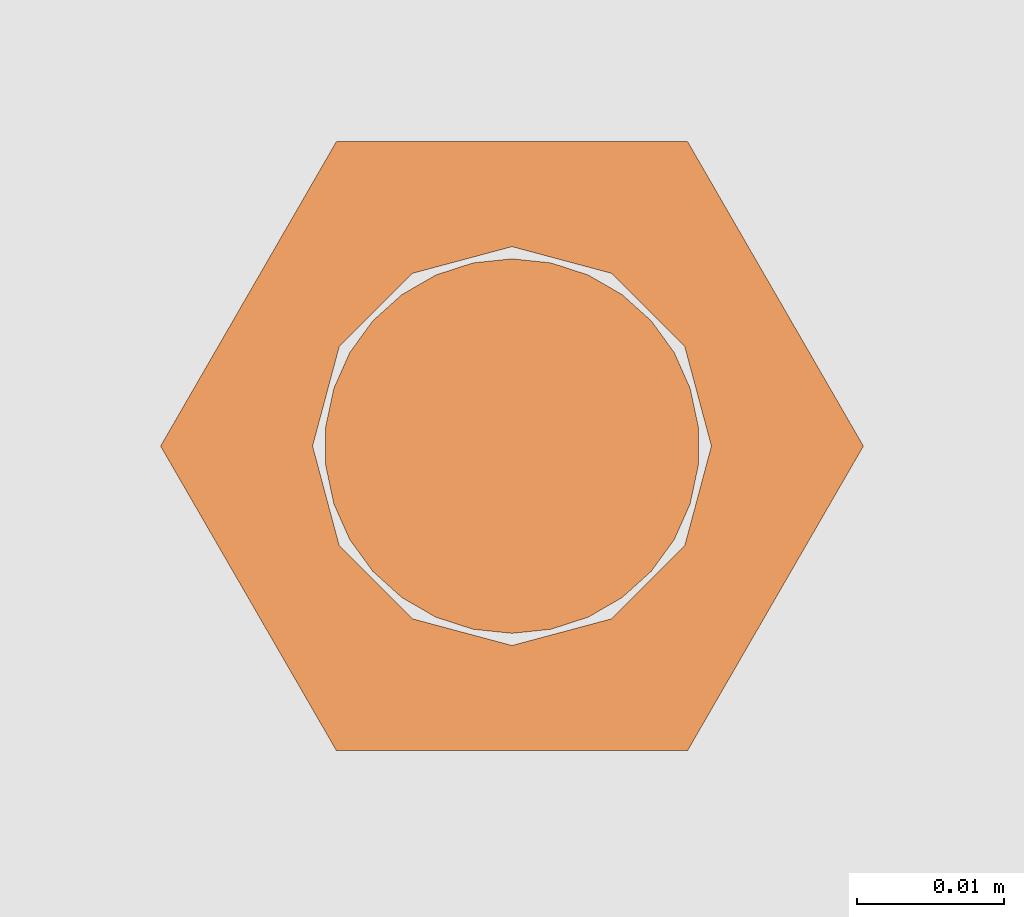
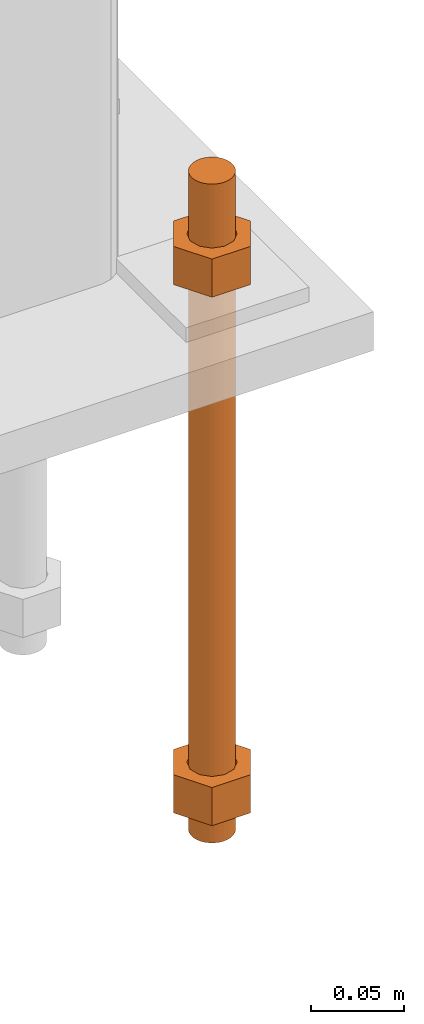
# One storey, part 23 of 89: 1 proxy.
"""IFC4 building model written with IfcOpenShell, lengths in feet."""

from ifc_helpers import new_model, entity, si_unit, converted_unit, derived_unit, direction, frame, origin, place, context, subcontext, project, spatial, faceted_brep, source, transform, mapped, material, constituent, constituent_set, type_object, type_shapes, element, save


model = new_model("IFC4")

# Units and contexts
model_context = context("Model", 3, precision=0.0001, world=origin(), true_north=direction((6.12303176911189e-17, 1.0)))
body_context = subcontext(model_context, "Body", "Model", "MODEL_VIEW")
ifc_project = project(units=[converted_unit("LENGTHUNIT", "FOOT", entity("IfcRatioMeasure", 0.3048), si_unit("LENGTHUNIT", "METRE"), dimensions=[1, 0, 0, 0, 0, 0, 0]), converted_unit("AREAUNIT", "SQUARE FOOT", entity("IfcRatioMeasure", 0.09290304), si_unit("AREAUNIT", "SQUARE_METRE"), dimensions=[2, 0, 0, 0, 0, 0, 0]), converted_unit("VOLUMEUNIT", "CUBIC FOOT", entity("IfcRatioMeasure", 0.028316846592), si_unit("VOLUMEUNIT", "CUBIC_METRE"), dimensions=[3, 0, 0, 0, 0, 0, 0]), si_unit("PLANEANGLEUNIT", "RADIAN"), si_unit("MASSUNIT", "GRAM", prefix="KILO"), derived_unit("MASSDENSITYUNIT", [(si_unit("MASSUNIT", "GRAM", prefix="KILO"), 1), (si_unit("LENGTHUNIT", "METRE"), -3)]), derived_unit("MOMENTOFINERTIAUNIT", [(si_unit("LENGTHUNIT", "METRE"), 4)]), si_unit("TIMEUNIT", "SECOND"), si_unit("FREQUENCYUNIT", "HERTZ"), si_unit("THERMODYNAMICTEMPERATUREUNIT", "DEGREE_CELSIUS"), derived_unit("THERMALTRANSMITTANCEUNIT", [(si_unit("MASSUNIT", "GRAM", prefix="KILO"), 1), (si_unit("THERMODYNAMICTEMPERATUREUNIT", "KELVIN"), -1), (si_unit("TIMEUNIT", "SECOND"), -3)]), derived_unit("VOLUMETRICFLOWRATEUNIT", [(si_unit("LENGTHUNIT", "METRE"), 3), (si_unit("TIMEUNIT", "SECOND"), -1)]), si_unit("ELECTRICCURRENTUNIT", "AMPERE"), si_unit("ELECTRICVOLTAGEUNIT", "VOLT"), si_unit("POWERUNIT", "WATT"), si_unit("FORCEUNIT", "NEWTON"), si_unit("ILLUMINANCEUNIT", "LUX"), si_unit("LUMINOUSFLUXUNIT", "LUMEN"), si_unit("LUMINOUSINTENSITYUNIT", "CANDELA"), derived_unit("USERDEFINED", [(si_unit("MASSUNIT", "GRAM", prefix="KILO"), -1), (si_unit("LENGTHUNIT", "METRE"), -2), (si_unit("TIMEUNIT", "SECOND"), 3), (si_unit("LUMINOUSFLUXUNIT", "LUMEN"), 1)]), derived_unit("LINEARVELOCITYUNIT", [(si_unit("LENGTHUNIT", "METRE"), 1), (si_unit("TIMEUNIT", "SECOND"), -1)]), si_unit("PRESSUREUNIT", "PASCAL"), derived_unit("USERDEFINED", [(si_unit("LENGTHUNIT", "METRE"), -2), (si_unit("MASSUNIT", "GRAM", prefix="KILO"), 1), (si_unit("TIMEUNIT", "SECOND"), -2)]), derived_unit("LINEARFORCEUNIT", [(si_unit("MASSUNIT", "GRAM", prefix="KILO"), 1), (si_unit("LENGTHUNIT", "METRE"), 1), (si_unit("TIMEUNIT", "SECOND"), -2), (si_unit("LENGTHUNIT", "METRE"), -1)]), derived_unit("PLANARFORCEUNIT", [(si_unit("MASSUNIT", "GRAM", prefix="KILO"), 1), (si_unit("LENGTHUNIT", "METRE"), 1), (si_unit("TIMEUNIT", "SECOND"), -2), (si_unit("LENGTHUNIT", "METRE"), -2)])], contexts=[model_context])

# Site, building, storey
site_placement = place(None, origin())
site = spatial("IfcSite", under=ifc_project, at=site_placement, CompositionType="ELEMENT")
building_placement = place(site_placement, frame((-472.238160486, -49.138065117, 0.0)))
building = spatial("IfcBuilding", under=site, at=building_placement, CompositionType="ELEMENT")
storey_placement = place(building_placement, origin())
storey = spatial("IfcBuildingStorey", under=building, at=storey_placement, Name="Level 1", CompositionType="ELEMENT", Elevation=0.0)

# Proxy
ifc_material_1 = material(Name="Color 7721", Category="Materials")
ifc_constituent_1 = constituent(ifc_material_1, Name="Color 7721", Category="Materials")
ifc_material_2 = material(Name="Color 7720", Category="Materials")
ifc_constituent_2 = constituent(ifc_material_2, Name="Color 7720", Category="Materials")
ifc_constituent_set = constituent_set(constituents=[ifc_constituent_1, ifc_constituent_2])
building_element_proxy_type = type_object("IfcBuildingElementProxyType", Name="rb2", PredefinedType="NOTDEFINED", material=ifc_material_1)
shared_shape = source(origin(), body_context, "Body", "Brep", [
    faceted_brep([(0.122545547339314, 0.0677083333333712, 0.0626666666666664), (0.156365697905585, 0.0677083333333712, 0.0626666666666664), (0.117274273429189, 0.135416666666742, 0.0626666666666664), (0.0390914244764531, 0.135416666666742, 0.0626666666666664), (0.0, 0.0677083333333712, 0.0626666666666664), (0.0338201505663278, 0.0677083333333712, 0.0626666666666664), (0.0397636251697122, 0.089889682526632, 0.0626666666666664), (0.0560014997595886, 0.106127557116452, 0.0626666666666664), (0.0781828489528209, 0.112071031719893, 0.0626666666666664), (0.100364198146053, 0.106127557116452, 0.0626666666666664), (0.11660207273593, 0.089889682526632, 0.0626666666666664), (0.117274273429189, 0.0, 0.0626666666666664), (0.0390914244764531, 0.0, 0.0626666666666664), (0.0397636251697122, 0.0455269841401105, 0.0626666666666664), (0.0560014997595886, 0.029289109550291, 0.0626666666666664), (0.0781828489528209, 0.0233456349468497, 0.0626666666666664), (0.100364198146053, 0.029289109550291, 0.0626666666666664), (0.11660207273593, 0.0455269841401105, 0.0626666666666664), (0.0, 0.0677083333333712, 0.144697916666667), (0.0390914244764815, 0.135416666666742, 0.144697916666667), (0.117274273429189, 0.135416666666742, 0.144697916666667), (0.156365697905613, 0.0677083333333712, 0.144697916666667), (0.117274273429217, 0.0, 0.144697916666667), (0.0390914244764531, 0.0, 0.144697916666667), (0.122545547339314, 0.0677083333333712, 0.144697916666666), (0.0338201505663278, 0.0677083333333712, 0.144697916666666), (0.0397636251697122, 0.0455269841401105, 0.144697916666666), (0.0560014997595886, 0.029289109550291, 0.144697916666666), (0.0781828489528209, 0.0233456349468497, 0.144697916666666), (0.100364198146053, 0.029289109550291, 0.144697916666666), (0.11660207273593, 0.0455269841401105, 0.144697916666666), (0.0397636251697122, 0.089889682526632, 0.144697916666666), (0.0560014997595886, 0.106127557116452, 0.144697916666666), (0.0781828489528209, 0.112071031719893, 0.144697916666666), (0.100364198146053, 0.106127557116452, 0.144697916666666), (0.11660207273593, 0.089889682526632, 0.144697916666666)], [[[0, 1, 2, 3, 4, 5, 6, 7, 8, 9, 10]], [[1, 11, 12, 4, 5, 13, 14, 15, 16, 17, 0]], [[4, 18, 19, 3]], [[3, 19, 20, 2]], [[2, 20, 21, 1]], [[1, 21, 22, 11]], [[11, 22, 23, 12]], [[12, 23, 18, 4]], [[24, 21, 22, 23, 18, 25, 26, 27, 28, 29, 30]], [[21, 20, 19, 18, 25, 31, 32, 33, 34, 35, 24]], [[25, 5, 6, 31]], [[31, 6, 7, 32]], [[32, 7, 8, 33]], [[33, 8, 9, 34]], [[34, 9, 10, 35]], [[35, 10, 0, 24]], [[24, 0, 17, 30]], [[30, 17, 16, 29]], [[29, 16, 15, 28]], [[28, 15, 14, 27]], [[27, 14, 13, 26]], [[26, 13, 5, 25]]]),
    faceted_brep([(0.0338201505663278, 0.0677083333333712, 1.28108333333333), (0.0, 0.0677083333333712, 1.28108333333333), (0.0390914244764531, 0.135416666666742, 1.28108333333333), (0.117274273429189, 0.135416666666742, 1.28108333333333), (0.156365697905585, 0.0677083333333712, 1.28108333333333), (0.122545547339314, 0.0677083333333712, 1.28108333333333), (0.11660207273593, 0.089889682526632, 1.28108333333333), (0.100364198146053, 0.106127557116452, 1.28108333333333), (0.0781828489528209, 0.112071031719893, 1.28108333333333), (0.0560014997595886, 0.106127557116452, 1.28108333333333), (0.0397636251697122, 0.089889682526632, 1.28108333333333), (0.0390914244764531, 0.0, 1.28108333333333), (0.117274273429189, 0.0, 1.28108333333333), (0.11660207273593, 0.0455269841401105, 1.28108333333333), (0.100364198146053, 0.029289109550291, 1.28108333333333), (0.0781828489528209, 0.0233456349468497, 1.28108333333333), (0.0560014997595886, 0.029289109550291, 1.28108333333333), (0.0397636251697122, 0.0455269841401105, 1.28108333333333), (0.156365697905557, 0.0677083333333712, 1.19905208333333), (0.11727427342916, 0.135416666666742, 1.19905208333333), (0.0390914244764531, 0.135416666666742, 1.19905208333333), (0.0, 0.0677083333333712, 1.19905208333333), (0.0390914244764247, 0.0, 1.19905208333333), (0.117274273429189, 0.0, 1.19905208333333), (0.0338201505663278, 0.0677083333333712, 1.19905208333333), (0.122545547339314, 0.0677083333333712, 1.19905208333333), (0.11660207273593, 0.0455269841401105, 1.19905208333333), (0.100364198146053, 0.029289109550291, 1.19905208333333), (0.0781828489528209, 0.0233456349468497, 1.19905208333333), (0.0560014997595886, 0.029289109550291, 1.19905208333333), (0.0397636251697122, 0.0455269841401105, 1.19905208333333), (0.11660207273593, 0.089889682526632, 1.19905208333333), (0.100364198146053, 0.106127557116452, 1.19905208333333), (0.0781828489528209, 0.112071031719893, 1.19905208333333), (0.0560014997595886, 0.106127557116452, 1.19905208333333), (0.0397636251697122, 0.089889682526632, 1.19905208333333)], [[[0, 1, 2, 3, 4, 5, 6, 7, 8, 9, 10]], [[1, 11, 12, 4, 5, 13, 14, 15, 16, 17, 0]], [[4, 18, 19, 3]], [[3, 19, 20, 2]], [[2, 20, 21, 1]], [[1, 21, 22, 11]], [[11, 22, 23, 12]], [[12, 23, 18, 4]], [[24, 21, 22, 23, 18, 25, 26, 27, 28, 29, 30]], [[21, 20, 19, 18, 25, 31, 32, 33, 34, 35, 24]], [[25, 5, 6, 31]], [[31, 6, 7, 32]], [[32, 7, 8, 33]], [[33, 8, 9, 34]], [[34, 9, 10, 35]], [[35, 10, 0, 24]], [[24, 0, 17, 30]], [[30, 17, 16, 29]], [[29, 16, 15, 28]], [[28, 15, 14, 27]], [[27, 14, 13, 26]], [[26, 13, 5, 25]]]),
    faceted_brep([(0.0781828489528209, 0.0260416666667425, 0.0), (0.0695198618354027, 0.0269521833027966, 0.0), (0.06123548882465, 0.029643939264929, 0.0), (0.0536917967739612, 0.0339992919010683, 0.0), (0.0472184812246041, 0.0398278914017283, 0.0), (0.0420984571284748, 0.046875, 0.0), (0.038555494107186, 0.0548326252344395, 0.0), (0.0367444366458187, 0.0633529806972319, 0.0), (0.0367444366458187, 0.0720636859695105, 0.0), (0.038555494107186, 0.0805840414323029, 0.0), (0.0420984571284748, 0.0885416666667425, 0.0), (0.0472184812246041, 0.0955887752650142, 0.0), (0.0536917967739612, 0.101417374765674, 0.0), (0.06123548882465, 0.105772727401813, 0.0), (0.0695198618354027, 0.108464483363946, 0.0), (0.0781828489528209, 0.109375, 0.0), (0.0868458360702391, 0.108464483363946, 0.0), (0.0951302090809918, 0.105772727401813, 0.0), (0.102673901131681, 0.101417374765674, 0.0), (0.109147216681038, 0.0955887752650142, 0.0), (0.114267240777167, 0.0885416666667425, 0.0), (0.117810203798456, 0.0805840414323029, 0.0), (0.119621261259823, 0.0720636859695105, 0.0), (0.119621261259823, 0.0633529806972319, 0.0), (0.117810203798456, 0.0548326252344395, 0.0), (0.114267240777167, 0.046875, 0.0), (0.109147216681038, 0.0398278914017283, 0.0), (0.102673901131681, 0.0339992919010683, 0.0), (0.0951302090809918, 0.029643939264929, 0.0), (0.0868458360702391, 0.0269521833027966, 0.0), (0.0868458360702391, 0.0269521833027966, 1.41666666666667), (0.0951302090809918, 0.029643939264929, 1.41666666666667), (0.102673901131681, 0.0339992919010683, 1.41666666666667), (0.109147216681038, 0.0398278914017283, 1.41666666666667), (0.114267240777167, 0.046875, 1.41666666666667), (0.117810203798456, 0.0548326252344395, 1.41666666666667), (0.119621261259823, 0.0633529806972319, 1.41666666666667), (0.119621261259823, 0.0720636859695105, 1.41666666666667), (0.117810203798456, 0.0805840414323029, 1.41666666666667), (0.114267240777167, 0.0885416666667425, 1.41666666666667), (0.109147216681038, 0.0955887752650142, 1.41666666666667), (0.102673901131681, 0.101417374765674, 1.41666666666667), (0.0951302090809918, 0.105772727401813, 1.41666666666667), (0.0868458360702391, 0.108464483363946, 1.41666666666667), (0.0781828489528209, 0.109375, 1.41666666666667), (0.0695198618354027, 0.108464483363946, 1.41666666666667), (0.06123548882465, 0.105772727401813, 1.41666666666667), (0.0536917967739612, 0.101417374765674, 1.41666666666667), (0.0472184812246041, 0.0955887752650142, 1.41666666666667), (0.0420984571284748, 0.0885416666667425, 1.41666666666667), (0.038555494107186, 0.0805840414323029, 1.41666666666667), (0.0367444366458187, 0.0720636859695105, 1.41666666666667), (0.0367444366458187, 0.0633529806972319, 1.41666666666667), (0.038555494107186, 0.0548326252344395, 1.41666666666667), (0.0420984571284748, 0.046875, 1.41666666666667), (0.0472184812246041, 0.0398278914017283, 1.41666666666667), (0.0536917967739612, 0.0339992919010683, 1.41666666666667), (0.06123548882465, 0.029643939264929, 1.41666666666667), (0.0695198618354027, 0.0269521833027966, 1.41666666666667), (0.0781828489528209, 0.0260416666667425, 1.41666666666667), (0.0695198618354027, 0.0269521833027966, 0.25), (0.0781828489528209, 0.0260416666667425, 0.25), (0.06123548882465, 0.029643939264929, 0.25), (0.0536917967739612, 0.0339992919010683, 0.25), (0.047218481224661, 0.0398278914017283, 0.25), (0.0420984571284464, 0.046875, 0.25), (0.038555494107186, 0.0548326252344395, 0.25), (0.0367444366457903, 0.0633529806972319, 0.25), (0.0367444366458187, 0.0720636859695105, 0.25), (0.038555494107186, 0.0805840414323029, 0.25), (0.0420984571285032, 0.0885416666667425, 0.25), (0.0472184812246041, 0.0955887752650142, 0.25), (0.0536917967739896, 0.101417374765674, 0.25), (0.06123548882465, 0.105772727401813, 0.25), (0.0695198618354027, 0.108464483363946, 0.25), (0.0781828489528209, 0.109375, 0.25), (0.0868458360702391, 0.108464483363946, 0.25), (0.0951302090809918, 0.105772727401813, 0.25), (0.102673901131681, 0.101417374765674, 0.25), (0.109147216681095, 0.0955887752650142, 0.25), (0.114267240777167, 0.0885416666667425, 0.25), (0.117810203798371, 0.0805840414323029, 0.25), (0.119621261259823, 0.0720636859695105, 0.25), (0.119621261259823, 0.0633529806972319, 0.25), (0.117810203798456, 0.0548326252344395, 0.25), (0.114267240777224, 0.046875, 0.25), (0.109147216681009, 0.0398278914017283, 0.25), (0.102673901131709, 0.0339992919010683, 0.25), (0.0951302090809918, 0.029643939264929, 0.25), (0.0868458360702391, 0.0269521833027966, 0.25), (0.0695198618354027, 0.0269521833027966, 0.916666666666667), (0.0781828489528209, 0.0260416666667425, 0.916666666666667), (0.06123548882465, 0.029643939264929, 0.916666666666667), (0.0536917967739612, 0.0339992919010683, 0.916666666666667), (0.047218481224661, 0.0398278914017283, 0.916666666666667), (0.0420984571284464, 0.046875, 0.916666666666667), (0.038555494107186, 0.0548326252344395, 0.916666666666667), (0.0367444366457903, 0.0633529806972319, 0.916666666666667), (0.0367444366458187, 0.0720636859695105, 0.916666666666667), (0.038555494107186, 0.0805840414323029, 0.916666666666667), (0.0420984571285032, 0.0885416666667425, 0.916666666666667), (0.0472184812246041, 0.0955887752650142, 0.916666666666667), (0.0536917967739896, 0.101417374765674, 0.916666666666667), (0.06123548882465, 0.105772727401813, 0.916666666666667), (0.0695198618354027, 0.108464483363946, 0.916666666666667), (0.0781828489528209, 0.109375, 0.916666666666667), (0.0868458360702391, 0.108464483363946, 0.916666666666667), (0.0951302090809918, 0.105772727401813, 0.916666666666667), (0.102673901131681, 0.101417374765674, 0.916666666666667), (0.109147216681095, 0.0955887752650142, 0.916666666666667), (0.114267240777167, 0.0885416666667425, 0.916666666666667), (0.117810203798371, 0.0805840414323029, 0.916666666666667), (0.119621261259823, 0.0720636859695105, 0.916666666666667), (0.119621261259823, 0.0633529806972319, 0.916666666666667), (0.117810203798456, 0.0548326252344395, 0.916666666666667), (0.114267240777224, 0.046875, 0.916666666666667), (0.109147216681009, 0.0398278914017283, 0.916666666666667), (0.102673901131709, 0.0339992919010683, 0.916666666666667), (0.0951302090809918, 0.029643939264929, 0.916666666666667), (0.0868458360702391, 0.0269521833027966, 0.916666666666667)], [[[0, 1, 2, 3, 4, 5, 6, 7, 8, 9, 10, 11, 12, 13, 14, 15, 16, 17, 18, 19, 20, 21, 22, 23, 24, 25, 26, 27, 28, 29]], [[30, 31, 32, 33, 34, 35, 36, 37, 38, 39, 40, 41, 42, 43, 44, 45, 46, 47, 48, 49, 50, 51, 52, 53, 54, 55, 56, 57, 58, 59]], [[60, 1, 0, 61]], [[62, 2, 1, 60]], [[63, 3, 2, 62]], [[64, 4, 3, 63]], [[65, 5, 4, 64]], [[66, 6, 5, 65]], [[67, 7, 6, 66]], [[68, 8, 7, 67]], [[69, 9, 8, 68]], [[70, 10, 9, 69]], [[71, 11, 10, 70]], [[72, 12, 11, 71]], [[73, 13, 12, 72]], [[74, 14, 13, 73]], [[75, 15, 14, 74]], [[76, 16, 15, 75]], [[77, 17, 16, 76]], [[78, 18, 17, 77]], [[79, 19, 18, 78]], [[80, 20, 19, 79]], [[81, 21, 20, 80]], [[82, 22, 21, 81]], [[83, 23, 22, 82]], [[84, 24, 23, 83]], [[85, 25, 24, 84]], [[86, 26, 25, 85]], [[87, 27, 26, 86]], [[88, 28, 27, 87]], [[89, 29, 28, 88]], [[61, 0, 29, 89]], [[90, 60, 61, 91]], [[92, 62, 60, 90]], [[93, 63, 62, 92]], [[94, 64, 63, 93]], [[95, 65, 64, 94]], [[96, 66, 65, 95]], [[97, 67, 66, 96]], [[98, 68, 67, 97]], [[99, 69, 68, 98]], [[100, 70, 69, 99]], [[101, 71, 70, 100]], [[102, 72, 71, 101]], [[103, 73, 72, 102]], [[104, 74, 73, 103]], [[105, 75, 74, 104]], [[106, 76, 75, 105]], [[107, 77, 76, 106]], [[108, 78, 77, 107]], [[109, 79, 78, 108]], [[110, 80, 79, 109]], [[111, 81, 80, 110]], [[112, 82, 81, 111]], [[113, 83, 82, 112]], [[114, 84, 83, 113]], [[115, 85, 84, 114]], [[116, 86, 85, 115]], [[117, 87, 86, 116]], [[118, 88, 87, 117]], [[119, 89, 88, 118]], [[91, 61, 89, 119]], [[58, 90, 91, 59]], [[57, 92, 90, 58]], [[56, 93, 92, 57]], [[55, 94, 93, 56]], [[54, 95, 94, 55]], [[53, 96, 95, 54]], [[52, 97, 96, 53]], [[51, 98, 97, 52]], [[50, 99, 98, 51]], [[49, 100, 99, 50]], [[48, 101, 100, 49]], [[47, 102, 101, 48]], [[46, 103, 102, 47]], [[45, 104, 103, 46]], [[44, 105, 104, 45]], [[43, 106, 105, 44]], [[42, 107, 106, 43]], [[41, 108, 107, 42]], [[40, 109, 108, 41]], [[39, 110, 109, 40]], [[38, 111, 110, 39]], [[37, 112, 111, 38]], [[36, 113, 112, 37]], [[35, 114, 113, 36]], [[34, 115, 114, 35]], [[33, 116, 115, 34]], [[32, 117, 116, 33]], [[31, 118, 117, 32]], [[30, 119, 118, 31]], [[59, 91, 119, 30]]]),
])
type_shapes(building_element_proxy_type, [shared_shape])
proxy_placement = place(building_placement, frame((206.984317151047, 996.651041666667, -1.45833333333333)))
element("IfcBuildingElementProxy", 1, at=proxy_placement, inside=storey, type_object=building_element_proxy_type, material=ifc_constituent_set, Name="rb2 483:rb2 483", ObjectType="rb2 483:rb2 483", PredefinedType="NOTDEFINED", context=body_context, shape_type="MappedRepresentation", body=[
    mapped(shared_shape, transform((0.0, 0.0, 0.0), scale=1.0)),
])

save(model, "model.ifc")
